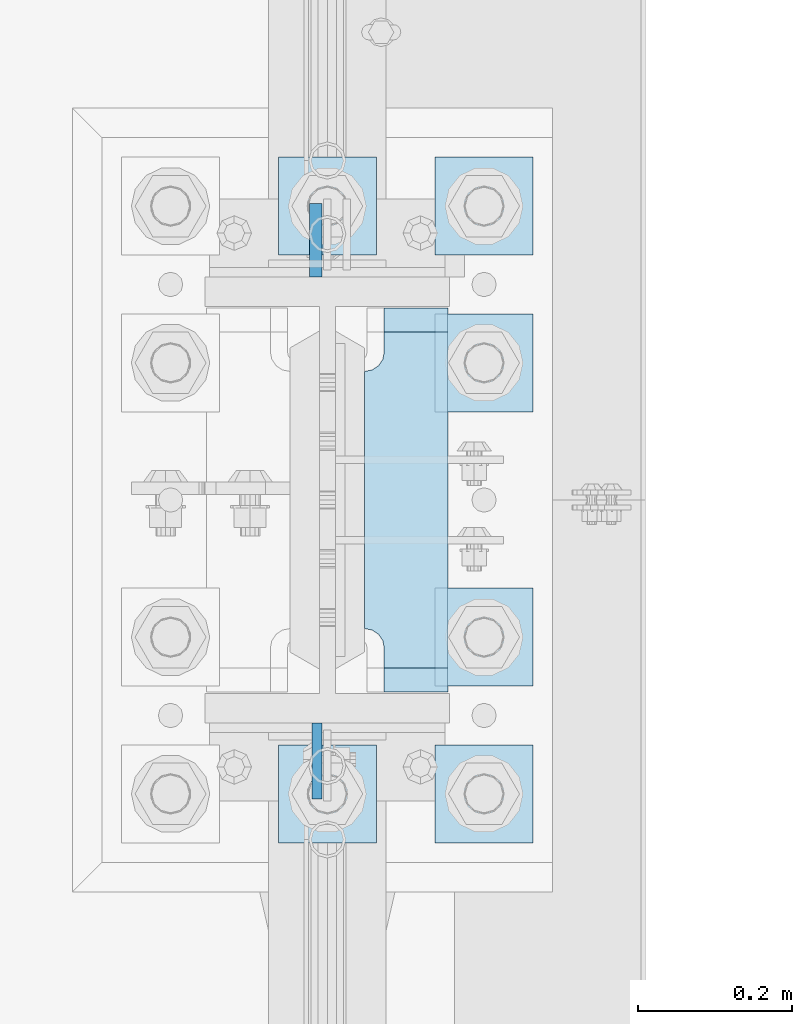
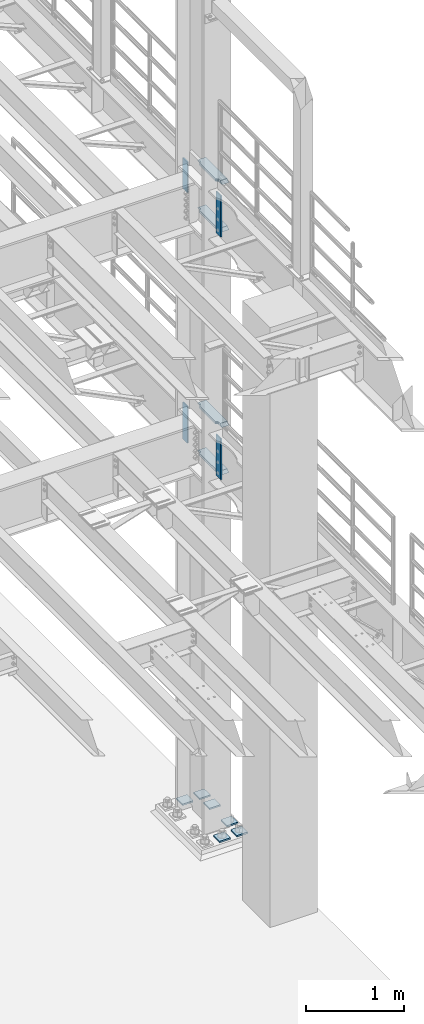
# One storey, part 1816 of 1876: 14 plates, 2 elements without a shape of their own.
"""IFC2X3 building model written with IfcOpenShell, lengths in millimetres."""

from ifc_helpers import new_model, si_unit, frame, origin_with_axes, place, context, subcontext, project, spatial, faceted_brep, material, type_object, element, aggregate, save


model = new_model("IFC2X3")

# Units and contexts
model_context = context("Model", 3, precision=1e-05, world=origin_with_axes())
body_context = subcontext(model_context, "Body", "Model", "MODEL_VIEW")
ifc_project = project(units=[si_unit("LENGTHUNIT", "METRE", prefix="MILLI"), si_unit("AREAUNIT", "SQUARE_METRE"), si_unit("VOLUMEUNIT", "CUBIC_METRE"), si_unit("MASSUNIT", "GRAM", prefix="KILO"), si_unit("TIMEUNIT", "SECOND"), si_unit("PLANEANGLEUNIT", "RADIAN"), si_unit("SOLIDANGLEUNIT", "STERADIAN"), si_unit("THERMODYNAMICTEMPERATUREUNIT", "DEGREE_CELSIUS"), si_unit("LUMINOUSINTENSITYUNIT", "LUMEN")], contexts=[model_context])

# Site, building, storey
site_placement = place(None, origin_with_axes())
site = spatial("IfcSite", under=ifc_project, at=site_placement, CompositionType="ELEMENT")
building_placement = place(site_placement, origin_with_axes())
building = spatial("IfcBuilding", under=site, at=building_placement, Name="Undefined", CompositionType="ELEMENT")
storey_placement = place(building_placement, origin_with_axes())
storey = spatial("IfcBuildingStorey", under=building, at=storey_placement, Name="Undefined", CompositionType="ELEMENT", Elevation=0.0)

# Assembly, plates
assembly_1_placement = place(storey_placement, origin_with_axes())
assembly_1 = element("IfcElementAssembly", 1, at=assembly_1_placement, inside=storey, Name="COLUMN", AssemblyPlace="NOTDEFINED", PredefinedType="RIGID_FRAME")
ifc_material_1 = material(Name="STEEL/A572-50")
plate_type_1 = type_object("IfcPlateType", PredefinedType="NOTDEFINED")
plate_1_placement = place(assembly_1_placement, frame((7606.50699987411, 7331.075, 8099.425), z_axis=(0.0, -1.0, 0.0), x_axis=(0.0, 0.0, -1.0)))
plate_1 = element("IfcPlate", 2, at=plate_1_placement, type_object=plate_type_1, material=ifc_material_1, Name="PLATE", context=body_context, shape_type="Brep", body=[
    faceted_brep([(0.0, -6.35000000000036, 0.0), (0.0, -6.34999999999991, 98.4250030517578), (0.0, 6.34999999999991, 98.4250030517578), (0.0, 6.35000000000036, 0.0), (514.349975585938, -6.35000000000036, 98.4250030517578), (514.349975585938, 6.35000000000036, 98.4250030517578), (514.349975585938, -6.35000000000036, 0.0), (514.349975585938, 6.35000000000036, 0.0)], [[[0, 1, 2, 3]], [[1, 4, 5, 2]], [[4, 6, 7, 5]], [[6, 0, 3, 7]], [[5, 7, 3, 2]], [[6, 4, 1, 0]]]),
])
plate_2_placement = place(assembly_1_placement, frame((7606.50699987411, 7331.075, 5076.825), z_axis=(0.0, -1.0, 0.0), x_axis=(0.0, 0.0, -1.0)))
plate_2 = element("IfcPlate", 3, at=plate_2_placement, type_object=plate_type_1, material=ifc_material_1, Name="PLATE", context=body_context, shape_type="Brep", body=[
    faceted_brep([(0.0, -6.35000000000036, 0.0), (0.0, -6.34999999999991, 98.4250030517578), (0.0, 6.34999999999991, 98.4250030517578), (0.0, 6.35000000000036, 0.0), (514.349975585938, -6.35000000000036, 98.4250030517578), (514.349975585938, 6.35000000000036, 98.4250030517578), (514.349975585938, -6.35000000000036, 0.0), (514.349975585938, 6.35000000000036, 0.0)], [[[0, 1, 2, 3]], [[1, 4, 5, 2]], [[4, 6, 7, 5]], [[6, 0, 3, 7]], [[5, 7, 3, 2]], [[6, 4, 1, 0]]]),
])
plate_type_2 = type_object("IfcPlateType", PredefinedType="NOTDEFINED")
plate_3_placement = place(assembly_1_placement, frame((7604.91949987411, 7908.925, 8108.95), z_axis=(0.0, 1.0, 0.0), x_axis=(0.0, 0.0, -1.0)))
plate_3 = element("IfcPlate", 4, at=plate_3_placement, type_object=plate_type_2, material=ifc_material_1, Name="PLATE", context=body_context, shape_type="Brep", body=[
    faceted_brep([(0.0, -7.9375, 0.0), (0.0, -7.9375, 95.25), (0.0, 7.9375, 95.25), (0.0, 7.9375, 0.0), (381.0, -7.9375, 95.25), (381.0, 7.9375, 95.25), (381.0, -7.9375, 0.0), (381.0, 7.9375, 0.0)], [[[0, 1, 2, 3]], [[1, 4, 5, 2]], [[4, 6, 7, 5]], [[6, 0, 3, 7]], [[5, 7, 3, 2]], [[6, 4, 1, 0]]]),
])
ifc_material_2 = material(Name="STEEL/A36")
plate_4_placement = place(assembly_1_placement, frame((7604.91949987411, 7908.925, 5067.3), z_axis=(0.0, 1.0, 0.0), x_axis=(0.0, 0.0, -1.0)))
plate_4 = element("IfcPlate", 5, at=plate_4_placement, type_object=plate_type_2, material=ifc_material_2, Name="PLATE", context=body_context, shape_type="Brep", body=[
    faceted_brep([(0.0, -7.9375, 0.0), (0.0, -7.9375, 95.25), (0.0, 7.9375, 95.25), (0.0, 7.9375, 0.0), (457.200012207031, -7.9375, 95.25), (457.200012207031, 7.9375, 95.25), (457.200012207031, -7.9375, 0.0), (457.200012207031, 7.9375, 0.0)], [[[0, 1, 2, 3]], [[1, 4, 5, 2]], [[4, 6, 7, 5]], [[6, 0, 3, 7]], [[5, 7, 3, 2]], [[6, 4, 1, 0]]]),
])
plate_type_3 = type_object("IfcPlateType", PredefinedType="NOTDEFINED")
plate_5_placement = place(assembly_1_placement, frame((7668.41875, 7869.2375, 7546.97501220703), z_axis=(0.0, -1.0, 0.0), x_axis=(1.0, 0.0, 0.0)))
plate_5 = element("IfcPlate", 6, at=plate_5_placement, type_object=plate_type_3, material=ifc_material_1, Name="PLATE", context=body_context, shape_type="Brep", body=[
    faceted_brep([(107.949996948242, -15.875, 498.475006103516), (107.949996948242, 15.875, 467.025007631571), (25.3999996185303, 15.875, 467.025007631571), (25.3999996185303, -15.875, 498.475006103516), (23.4665397733561, -15.875, 431.604843634198), (25.3999996185303, -15.875, 441.325002670288), (25.3999996185303, 15.875, 441.325002670288), (23.4665397733561, 15.875, 431.604843634198), (17.9605119724001, -15.875, 423.36449069789), (17.9605119724001, 15.875, 423.36449069789), (9.72015903609281, -15.875, 417.858462896934), (9.72015903609281, 15.875, 417.858462896934), (0.0, -15.875, 415.925003051758), (0.0, 15.875, 415.925003051758), (0.0, -15.875, 82.5500030517578), (0.0, 15.875, 82.5500030517578), (9.72015903609099, -15.875, 80.616543206582), (9.72015903609099, 15.875, 80.616543206582), (17.9605119723983, -15.875, 75.1105154056258), (17.9605119723983, 15.875, 75.1105154056258), (23.4665397733552, -15.875, 66.8701624693183), (23.4665397733552, 15.875, 66.8701624693183), (25.3999996185303, -15.875, 57.1500034332275), (25.3999996185303, 15.875, 57.1500034332275), (25.3999996185303, 15.875, 31.449998471945), (25.3999996185303, -15.875, 0.0), (107.949996948242, 15.875, 31.449998471945), (107.949996948242, -15.875, 0.0)], [[[0, 1, 2, 3]], [[4, 5, 6, 7]], [[8, 4, 7, 9]], [[10, 8, 9, 11]], [[12, 10, 11, 13]], [[14, 12, 13, 15]], [[16, 14, 15, 17]], [[18, 16, 17, 19]], [[20, 18, 19, 21]], [[22, 20, 21, 23]], [[22, 23, 24, 25]], [[26, 27, 25, 24]], [[5, 4, 8, 10, 12, 14, 16, 18, 20, 22, 25, 27, 0, 3]], [[6, 5, 3, 2]], [[26, 24, 23, 21, 19, 17, 15, 13, 11, 9, 7, 6, 2, 1]], [[27, 26, 1, 0]]]),
])
plate_6_placement = place(assembly_1_placement, frame((7668.41875, 7869.2375, 8137.525), z_axis=(0.0, -1.0, 0.0), x_axis=(1.0, 0.0, 0.0)))
plate_6 = element("IfcPlate", 7, at=plate_6_placement, type_object=plate_type_3, material=ifc_material_1, Name="PLATE", context=body_context, shape_type="Brep", body=[
    faceted_brep([(107.949996948242, -15.875, 498.475006103516), (107.949996948242, 15.875, 467.025007631571), (25.3999996185303, 15.875, 467.025007631571), (25.3999996185303, -15.875, 498.475006103516), (23.4665397733561, -15.875, 431.604843634198), (25.3999996185303, -15.875, 441.325002670288), (25.3999996185303, 15.875, 441.325002670288), (23.4665397733561, 15.875, 431.604843634198), (17.9605119724001, -15.875, 423.36449069789), (17.9605119724001, 15.875, 423.36449069789), (9.72015903609281, -15.875, 417.858462896934), (9.72015903609281, 15.875, 417.858462896934), (0.0, -15.875, 415.925003051758), (0.0, 15.875, 415.925003051758), (0.0, -15.875, 82.5500030517578), (0.0, 15.875, 82.5500030517578), (9.72015903609099, -15.875, 80.616543206582), (9.72015903609099, 15.875, 80.616543206582), (17.9605119723983, -15.875, 75.1105154056258), (17.9605119723983, 15.875, 75.1105154056258), (23.4665397733552, -15.875, 66.8701624693183), (23.4665397733552, 15.875, 66.8701624693183), (25.3999996185303, -15.875, 57.1500034332275), (25.3999996185303, 15.875, 57.1500034332275), (25.3999996185303, 15.875, 31.449998471945), (25.3999996185303, -15.875, 0.0), (107.949996948242, 15.875, 31.449998471945), (107.949996948242, -15.875, 0.0)], [[[0, 1, 2, 3]], [[4, 5, 6, 7]], [[8, 4, 7, 9]], [[10, 8, 9, 11]], [[12, 10, 11, 13]], [[14, 12, 13, 15]], [[16, 14, 15, 17]], [[18, 16, 17, 19]], [[20, 18, 19, 21]], [[22, 20, 21, 23]], [[22, 23, 24, 25]], [[26, 27, 25, 24]], [[5, 4, 8, 10, 12, 14, 16, 18, 20, 22, 25, 27, 0, 3]], [[6, 5, 3, 2]], [[26, 24, 23, 21, 19, 17, 15, 13, 11, 9, 7, 6, 2, 1]], [[27, 26, 1, 0]]]),
])
plate_7_placement = place(assembly_1_placement, frame((7668.41875, 7869.2375, 4524.37501220703), z_axis=(0.0, -1.0, 0.0), x_axis=(1.0, 0.0, 0.0)))
plate_7 = element("IfcPlate", 8, at=plate_7_placement, type_object=plate_type_3, material=ifc_material_1, Name="PLATE", context=body_context, shape_type="Brep", body=[
    faceted_brep([(107.949996948242, -15.875, 498.475006103516), (107.949996948242, 15.875, 467.025007631571), (25.3999996185303, 15.875, 467.025007631571), (25.3999996185303, -15.875, 498.475006103516), (23.4665397733561, -15.875, 431.604843634198), (25.3999996185303, -15.875, 441.325002670288), (25.3999996185303, 15.875, 441.325002670288), (23.4665397733561, 15.875, 431.604843634198), (17.9605119724001, -15.875, 423.36449069789), (17.9605119724001, 15.875, 423.36449069789), (9.72015903609281, -15.875, 417.858462896934), (9.72015903609281, 15.875, 417.858462896934), (0.0, -15.875, 415.925003051758), (0.0, 15.875, 415.925003051758), (0.0, -15.875, 82.5500030517578), (0.0, 15.875, 82.5500030517578), (9.72015903609099, -15.875, 80.616543206582), (9.72015903609099, 15.875, 80.616543206582), (17.9605119723983, -15.875, 75.1105154056258), (17.9605119723983, 15.875, 75.1105154056258), (23.4665397733552, -15.875, 66.8701624693183), (23.4665397733552, 15.875, 66.8701624693183), (25.3999996185303, -15.875, 57.1500034332275), (25.3999996185303, 15.875, 57.1500034332275), (25.3999996185303, 15.875, 31.449998471945), (25.3999996185303, -15.875, 0.0), (107.949996948242, 15.875, 31.449998471945), (107.949996948242, -15.875, 0.0)], [[[0, 1, 2, 3]], [[4, 5, 6, 7]], [[8, 4, 7, 9]], [[10, 8, 9, 11]], [[12, 10, 11, 13]], [[14, 12, 13, 15]], [[16, 14, 15, 17]], [[18, 16, 17, 19]], [[20, 18, 19, 21]], [[22, 20, 21, 23]], [[22, 23, 24, 25]], [[26, 27, 25, 24]], [[5, 4, 8, 10, 12, 14, 16, 18, 20, 22, 25, 27, 0, 3]], [[6, 5, 3, 2]], [[26, 24, 23, 21, 19, 17, 15, 13, 11, 9, 7, 6, 2, 1]], [[27, 26, 1, 0]]]),
])
plate_8_placement = place(assembly_1_placement, frame((7668.41875, 7869.2375, 5114.925), z_axis=(0.0, -1.0, 0.0), x_axis=(1.0, 0.0, 0.0)))
plate_8 = element("IfcPlate", 9, at=plate_8_placement, type_object=plate_type_3, material=ifc_material_1, Name="PLATE", context=body_context, shape_type="Brep", body=[
    faceted_brep([(107.949996948242, -15.875, 498.475006103516), (107.949996948242, 15.875, 467.025007631571), (25.3999996185303, 15.875, 467.025007631571), (25.3999996185303, -15.875, 498.475006103516), (23.4665397733561, -15.875, 431.604843634198), (25.3999996185303, -15.875, 441.325002670288), (25.3999996185303, 15.875, 441.325002670288), (23.4665397733561, 15.875, 431.604843634198), (17.9605119724001, -15.875, 423.36449069789), (17.9605119724001, 15.875, 423.36449069789), (9.72015903609281, -15.875, 417.858462896934), (9.72015903609281, 15.875, 417.858462896934), (0.0, -15.875, 415.925003051758), (0.0, 15.875, 415.925003051758), (0.0, -15.875, 82.5500030517578), (0.0, 15.875, 82.5500030517578), (9.72015903609099, -15.875, 80.616543206582), (9.72015903609099, 15.875, 80.616543206582), (17.9605119723983, -15.875, 75.1105154056258), (17.9605119723983, 15.875, 75.1105154056258), (23.4665397733552, -15.875, 66.8701624693183), (23.4665397733552, 15.875, 66.8701624693183), (25.3999996185303, -15.875, 57.1500034332275), (25.3999996185303, 15.875, 57.1500034332275), (25.3999996185303, 15.875, 31.449998471945), (25.3999996185303, -15.875, 0.0), (107.949996948242, 15.875, 31.449998471945), (107.949996948242, -15.875, 0.0)], [[[0, 1, 2, 3]], [[4, 5, 6, 7]], [[8, 4, 7, 9]], [[10, 8, 9, 11]], [[12, 10, 11, 13]], [[14, 12, 13, 15]], [[16, 14, 15, 17]], [[18, 16, 17, 19]], [[20, 18, 19, 21]], [[22, 20, 21, 23]], [[22, 23, 24, 25]], [[26, 27, 25, 24]], [[5, 4, 8, 10, 12, 14, 16, 18, 20, 22, 25, 27, 0, 3]], [[6, 5, 3, 2]], [[26, 24, 23, 21, 19, 17, 15, 13, 11, 9, 7, 6, 2, 1]], [[27, 26, 1, 0]]]),
])
aggregate(assembly_1, [plate_1, plate_5, plate_6, plate_3, plate_2, plate_7, plate_8, plate_4])

assembly_2_placement = place(storey_placement, origin_with_axes())
assembly_2 = element("IfcElementAssembly", 10, at=assembly_2_placement, inside=storey, Name="TEMPLATE", AssemblyPlace="NOTDEFINED", PredefinedType="RIGID_FRAME")
plate_type_4 = type_object("IfcPlateType", PredefinedType="NOTDEFINED")
plate_9_placement = place(assembly_2_placement, frame((7683.5, 7302.5, 104.775), z_axis=(-1.0, 0.0, 0.0), x_axis=(0.0, -1.0, 0.0)))
plate_9 = element("IfcPlate", 11, at=plate_9_placement, type_object=plate_type_4, material=ifc_material_1, Name="PLATE WASHER", context=body_context, shape_type="Brep", body=[
    faceted_brep([(-9.09494701772928e-13, -9.525, -1.81898940354586e-12), (0.0, -9.52500000000001, 127.0), (0.0, 9.52500000000001, 127.0), (-9.09494701772928e-13, 9.525, -1.81898940354586e-12), (127.0, -9.52500000000001, 127.0), (127.0, 9.52500000000001, 127.0), (127.0, -9.52500000000001, 0.0), (127.0, 9.52500000000001, 0.0)], [[[0, 1, 2, 3]], [[1, 4, 5, 2]], [[4, 6, 7, 5]], [[6, 0, 3, 7]], [[5, 7, 3, 2]], [[6, 4, 1, 0]]]),
])
plate_10_placement = place(assembly_2_placement, frame((7886.7, 7302.5, 104.775), z_axis=(-1.0, 0.0, 0.0), x_axis=(0.0, -1.0, 0.0)))
plate_10 = element("IfcPlate", 12, at=plate_10_placement, type_object=plate_type_4, material=ifc_material_1, Name="PLATE WASHER", context=body_context, shape_type="Brep", body=[
    faceted_brep([(-9.09494701772928e-13, -9.525, -1.81898940354586e-12), (0.0, -9.52500000000001, 127.0), (0.0, 9.52500000000001, 127.0), (-9.09494701772928e-13, 9.525, -1.81898940354586e-12), (127.0, -9.52500000000001, 127.0), (127.0, 9.52500000000001, 127.0), (127.0, -9.52500000000001, 0.0), (127.0, 9.52500000000001, 0.0)], [[[0, 1, 2, 3]], [[1, 4, 5, 2]], [[4, 6, 7, 5]], [[6, 0, 3, 7]], [[5, 7, 3, 2]], [[6, 4, 1, 0]]]),
])
plate_11_placement = place(assembly_2_placement, frame((7886.7, 7505.7, 104.775), z_axis=(-1.0, 0.0, 0.0), x_axis=(0.0, -1.0, 0.0)))
plate_11 = element("IfcPlate", 13, at=plate_11_placement, type_object=plate_type_4, material=ifc_material_1, Name="PLATE WASHER", context=body_context, shape_type="Brep", body=[
    faceted_brep([(-9.09494701772928e-13, -9.525, -1.81898940354586e-12), (0.0, -9.52500000000001, 127.0), (0.0, 9.52500000000001, 127.0), (-9.09494701772928e-13, 9.525, -1.81898940354586e-12), (127.0, -9.52500000000001, 127.0), (127.0, 9.52500000000001, 127.0), (127.0, -9.52500000000001, 0.0), (127.0, 9.52500000000001, 0.0)], [[[0, 1, 2, 3]], [[1, 4, 5, 2]], [[4, 6, 7, 5]], [[6, 0, 3, 7]], [[5, 7, 3, 2]], [[6, 4, 1, 0]]]),
])
plate_12_placement = place(assembly_2_placement, frame((7886.7, 7861.3, 104.775), z_axis=(-1.0, 0.0, 0.0), x_axis=(0.0, -1.0, 0.0)))
plate_12 = element("IfcPlate", 14, at=plate_12_placement, type_object=plate_type_4, material=ifc_material_1, Name="PLATE WASHER", context=body_context, shape_type="Brep", body=[
    faceted_brep([(-9.09494701772928e-13, -9.525, -1.81898940354586e-12), (0.0, -9.52500000000001, 127.0), (0.0, 9.52500000000001, 127.0), (-9.09494701772928e-13, 9.525, -1.81898940354586e-12), (127.0, -9.52500000000001, 127.0), (127.0, 9.52500000000001, 127.0), (127.0, -9.52500000000001, 0.0), (127.0, 9.52500000000001, 0.0)], [[[0, 1, 2, 3]], [[1, 4, 5, 2]], [[4, 6, 7, 5]], [[6, 0, 3, 7]], [[5, 7, 3, 2]], [[6, 4, 1, 0]]]),
])
plate_13_placement = place(assembly_2_placement, frame((7683.5, 8064.5, 104.775), z_axis=(-1.0, 0.0, 0.0), x_axis=(0.0, -1.0, 0.0)))
plate_13 = element("IfcPlate", 15, at=plate_13_placement, type_object=plate_type_4, material=ifc_material_1, Name="PLATE WASHER", context=body_context, shape_type="Brep", body=[
    faceted_brep([(-9.09494701772928e-13, -9.525, -1.81898940354586e-12), (0.0, -9.52500000000001, 127.0), (0.0, 9.52500000000001, 127.0), (-9.09494701772928e-13, 9.525, -1.81898940354586e-12), (127.0, -9.52500000000001, 127.0), (127.0, 9.52500000000001, 127.0), (127.0, -9.52500000000001, 0.0), (127.0, 9.52500000000001, 0.0)], [[[0, 1, 2, 3]], [[1, 4, 5, 2]], [[4, 6, 7, 5]], [[6, 0, 3, 7]], [[5, 7, 3, 2]], [[6, 4, 1, 0]]]),
])
plate_14_placement = place(assembly_2_placement, frame((7886.7, 8064.5, 104.775), z_axis=(-1.0, 0.0, 0.0), x_axis=(0.0, -1.0, 0.0)))
plate_14 = element("IfcPlate", 16, at=plate_14_placement, type_object=plate_type_4, material=ifc_material_1, Name="PLATE WASHER", context=body_context, shape_type="Brep", body=[
    faceted_brep([(-9.09494701772928e-13, -9.525, -1.81898940354586e-12), (0.0, -9.52500000000001, 127.0), (0.0, 9.52500000000001, 127.0), (-9.09494701772928e-13, 9.525, -1.81898940354586e-12), (127.0, -9.52500000000001, 127.0), (127.0, 9.52500000000001, 127.0), (127.0, -9.52500000000001, 0.0), (127.0, 9.52500000000001, 0.0)], [[[0, 1, 2, 3]], [[1, 4, 5, 2]], [[4, 6, 7, 5]], [[6, 0, 3, 7]], [[5, 7, 3, 2]], [[6, 4, 1, 0]]]),
])
aggregate(assembly_2, [plate_9, plate_10, plate_11, plate_12, plate_13, plate_14])

save(model, "model.ifc")
